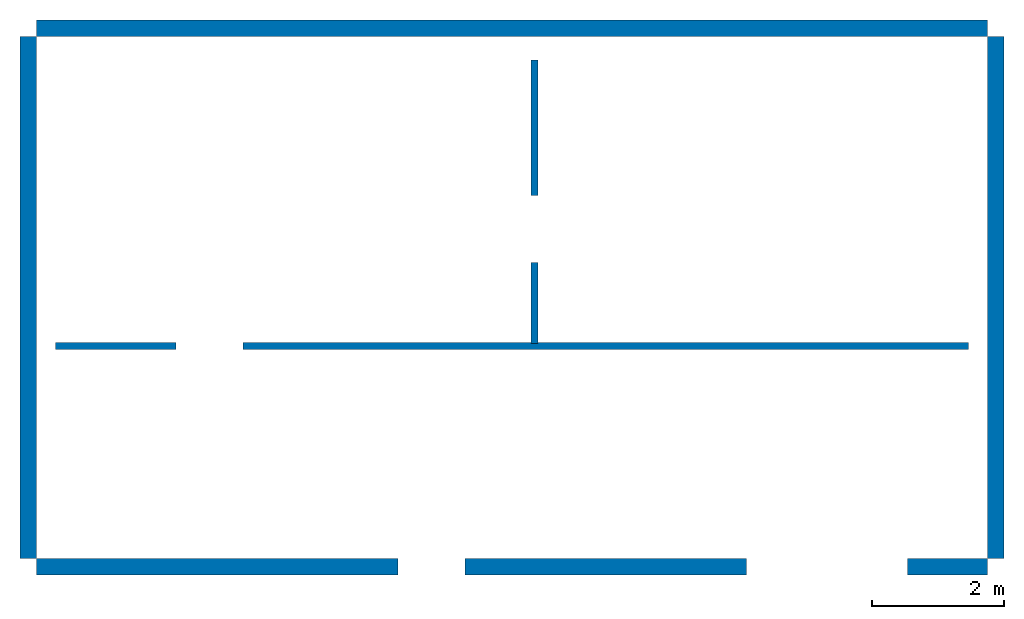
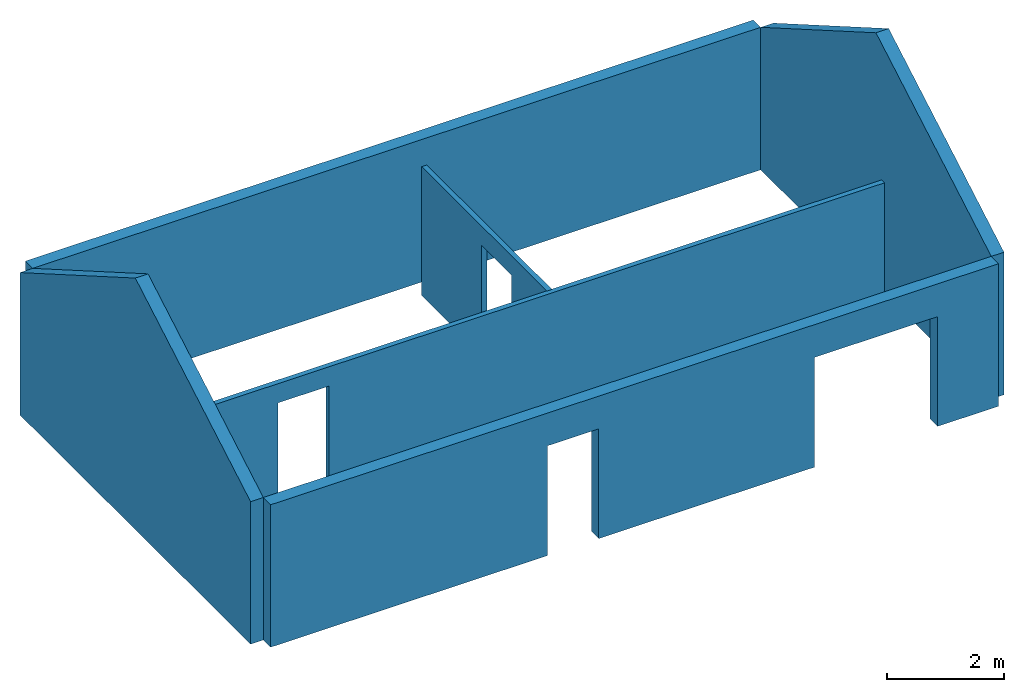
# One storey: 6 walls, 4 openings.
"""IFC4 building model written with IfcOpenShell, lengths in millimetres."""

from ifc_helpers import new_model, si_unit, frame, frame_2d, origin_with_axes, origin_2d, place, context, subcontext, project, spatial, rectangle, extrude, faceted_brep, element, save


model = new_model("IFC4")

# Units and contexts
model_context = context("Model", 3, precision=1e-05, world=origin_with_axes())
body_context = subcontext(model_context, "Body", "Model", "MODEL_VIEW")
ifc_project = project(units=[si_unit("AREAUNIT", "SQUARE_METRE"), si_unit("VOLUMEUNIT", "CUBIC_METRE"), si_unit("LENGTHUNIT", "METRE", prefix="MILLI")], contexts=[model_context])

# Site, building, storey
site = spatial("IfcSite", under=ifc_project)
building = spatial("IfcBuilding", under=site, Name="Building")
storey = spatial("IfcBuildingStorey", under=building, Name="Ground Floor", Elevation=0.0)

# Wall, openings
wall_1_placement = place(None, frame((0.0, -126.0, 0.0), z_axis=(0.0, 0.0, 1.0), x_axis=(1.0, 0.0, 0.0)))
wall_1 = element("IfcWall", 1, at=wall_1_placement, inside=storey, Name="Wall 1", context=body_context, shape_type="SweptSolid", body=[
    extrude(rectangle(XDim=14408.4, YDim=252.0, at=frame_2d((7204.2, 0.0))), None, (0.0, 0.0, 1.0), 2982.0),
])
opening_1_placement = place(wall_1_placement, frame((5985.0, 0.0, 0.0), z_axis=(0.0, 0.0, 1.0), x_axis=(1.0, 0.0, 0.0)))
element("IfcOpeningElement", 2, at=opening_1_placement, cuts=wall_1, Name="Opening 1", context=body_context, shape_type="SweptSolid", body=[
    extrude(rectangle(XDim=1016.0, YDim=272.0, at=origin_2d()), None, (0.0, 0.0, 1.0), 2297.0),
])
opening_2_placement = place(wall_1_placement, frame((11979.4, 0.0, 0.0), z_axis=(0.0, 0.0, 1.0), x_axis=(1.0, 0.0, 0.0)))
element("IfcOpeningElement", 3, at=opening_2_placement, cuts=wall_1, Name="Opening 2", context=body_context, shape_type="SweptSolid", body=[
    extrude(rectangle(XDim=2438.4, YDim=272.0, at=origin_2d()), None, (0.0, 0.0, 1.0), 2297.0),
])

# Walls
wall_2_placement = place(None, frame((14534.4, 2.02623453859256e-14, 0.0), z_axis=(0.0, 0.0, 1.0), x_axis=(-1.60812264967664e-16, 1.0, 0.0)))
element("IfcWall", 4, at=wall_2_placement, inside=storey, Name="Wall 2", context=body_context, shape_type="Brep", body=[
    faceted_brep([(0.0, -126.0, 0.0), (0.0, 126.0, 0.0), (7906.0, 126.0, 0.0), (7906.0, -126.0, 0.0), (0.0, -126.0, 2982.0), (3953.0, -126.0, 5264.26561410659), (7906.0, -126.0, 2982.0), (3953.0, 126.0, 5264.26561410659), (7906.0, 126.0, 2982.0), (0.0, 126.0, 2982.0)], [[[0, 1, 2, 3]], [[4, 5, 6]], [[6, 5, 7, 8]], [[9, 7, 5, 4]], [[8, 7, 9]], [[0, 3, 6, 5, 4]], [[1, 9, 7, 8, 2]], [[0, 4, 9, 1]], [[3, 2, 8, 6]]]),
])
wall_3_placement = place(None, frame((14408.4, 8032.0, 0.0), z_axis=(0.0, 0.0, 1.0), x_axis=(-1.0, -1.22464679914735e-16, 0.0)))
element("IfcWall", 5, at=wall_3_placement, inside=storey, Name="Wall 3", context=body_context, shape_type="SweptSolid", body=[
    extrude(rectangle(XDim=14408.4, YDim=252.0, at=frame_2d((7204.2, 0.0))), None, (0.0, 0.0, 1.0), 2982.0),
])
wall_4_placement = place(None, frame((-126.000000000002, 7906.0, 0.0), z_axis=(0.0, 0.0, 1.0), x_axis=(6.12323399573677e-17, -1.0, 0.0)))
element("IfcWall", 6, at=wall_4_placement, inside=storey, Name="Wall 4", context=body_context, shape_type="Brep", body=[
    faceted_brep([(0.0, -126.0, 0.0), (0.0, 126.0, 0.0), (7906.0, 126.0, 0.0), (7906.0, -126.0, 0.0), (0.0, -126.0, 2982.0), (3953.0, -126.0, 5264.26561410659), (7906.0, -126.0, 2982.0), (3953.0, 126.0, 5264.26561410659), (7906.0, 126.0, 2982.0), (0.0, 126.0, 2982.0)], [[[0, 1, 2, 3]], [[4, 5, 6]], [[6, 5, 7, 8]], [[9, 7, 5, 4]], [[8, 7, 9]], [[0, 3, 6, 5, 4]], [[1, 9, 7, 8, 2]], [[0, 4, 9, 1]], [[3, 2, 8, 6]]]),
])

# Wall, opening
wall_5_placement = place(None, frame((285.999999999998, 3217.62882260366, 0.0), z_axis=(0.0, 0.0, 1.0), x_axis=(1.0, 0.0, 0.0)))
wall_5 = element("IfcWall", 7, at=wall_5_placement, inside=storey, Name="Internal Wall 1", context=body_context, shape_type="SweptSolid", body=[
    extrude(rectangle(XDim=13836.4, YDim=100.0, at=frame_2d((6918.2, 0.0))), None, (0.0, 0.0, 1.0), 2700.0),
])
opening_3_placement = place(wall_5_placement, frame((2337.0, 0.0, 0.0), z_axis=(0.0, 0.0, 1.0), x_axis=(1.0, 0.0, 0.0)))
element("IfcOpeningElement", 8, at=opening_3_placement, cuts=wall_5, Name="Opening 1", context=body_context, shape_type="SweptSolid", body=[
    extrude(rectangle(XDim=1016.0, YDim=120.0, at=origin_2d()), None, (0.0, 0.0, 1.0), 2297.0),
])

wall_6_placement = place(None, frame((7545.62929133489, 7552.93933529898, 0.0), z_axis=(0.0, 0.0, 1.0), x_axis=(6.12323399573677e-17, -1.0, 0.0)))
wall_6 = element("IfcWall", 9, at=wall_6_placement, inside=storey, Name="Internal Wall 2", context=body_context, shape_type="SweptSolid", body=[
    extrude(rectangle(XDim=4295.31051269531, YDim=100.0, at=frame_2d((2147.65525634766, 0.0))), None, (0.0, 0.0, 1.0), 2700.0),
])
opening_4_placement = place(wall_6_placement, frame((2565.0, 0.0, 0.0), z_axis=(0.0, 0.0, 1.0), x_axis=(1.0, 0.0, 0.0)))
element("IfcOpeningElement", 10, at=opening_4_placement, cuts=wall_6, Name="Opening 1", context=body_context, shape_type="SweptSolid", body=[
    extrude(rectangle(XDim=1016.0, YDim=120.0, at=origin_2d()), None, (0.0, 0.0, 1.0), 2297.0),
])

save(model, "model.ifc")
